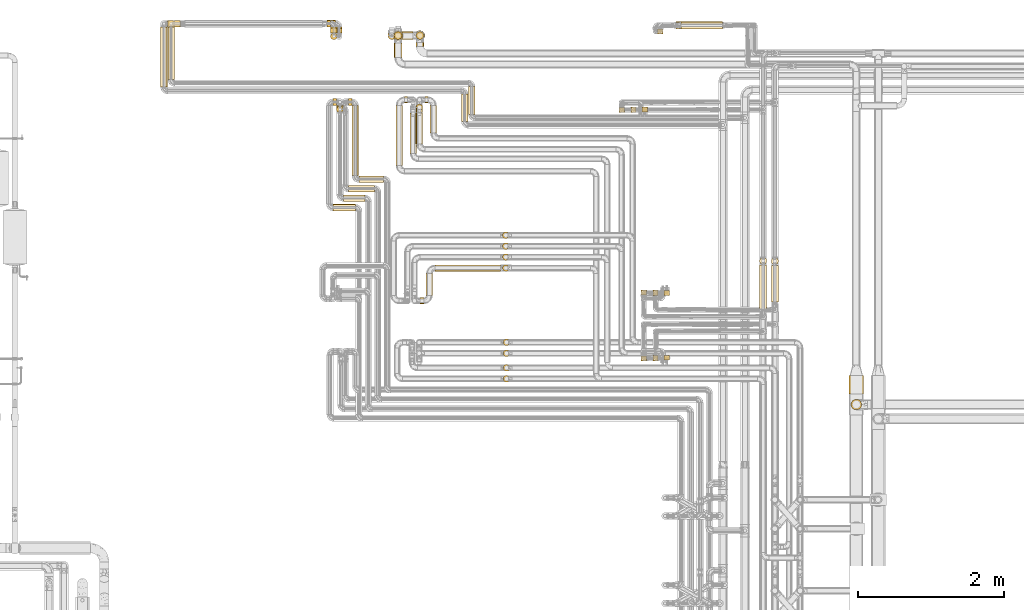
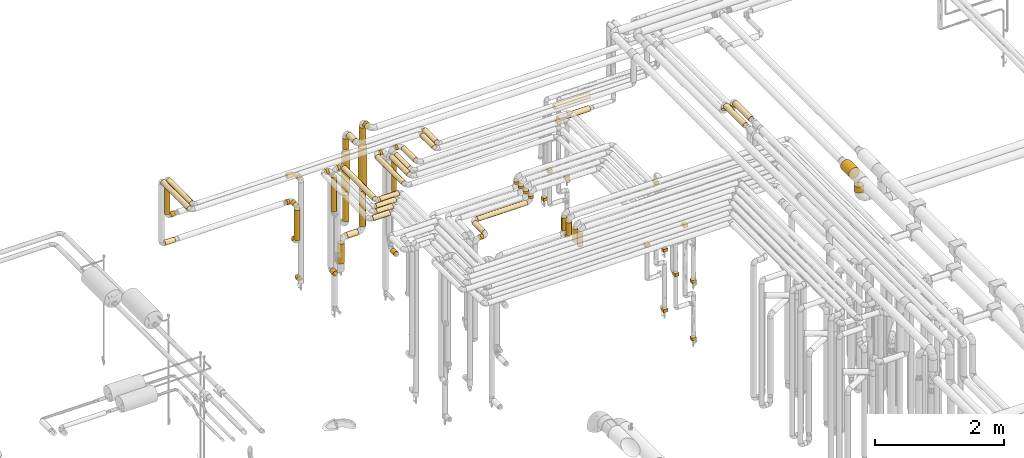
# One storey, part 14 of 827: 73 coverings.
"""IFC2X3 building model written with IfcOpenShell, lengths in millimetres."""

from ifc_helpers import new_model, entity, si_unit, converted_unit, derived_unit, direction, frame, origin, origin_2d_with_axis, place, context, subcontext, project, spatial, rectangle, circle, extrude, element, save


model = new_model("IFC2X3")

# Units and contexts
model_context = context("Model", 3, precision=0.01, world=origin(), true_north=direction((6.12303176911189e-17, 1.0)))
body_context = subcontext(model_context, "Body", "Model", "MODEL_VIEW")
ifc_project = project(units=[si_unit("LENGTHUNIT", "METRE", prefix="MILLI"), si_unit("AREAUNIT", "SQUARE_METRE"), si_unit("VOLUMEUNIT", "CUBIC_METRE"), converted_unit("PLANEANGLEUNIT", "DEGREE", entity("IfcRatioMeasure", 0.0174532925199433), si_unit("PLANEANGLEUNIT", "RADIAN"), dimensions=[0, 0, 0, 0, 0, 0, 0]), si_unit("MASSUNIT", "GRAM", prefix="KILO"), derived_unit("MASSDENSITYUNIT", [(si_unit("MASSUNIT", "GRAM", prefix="KILO"), 1), (si_unit("LENGTHUNIT", "METRE"), -3)]), derived_unit("MOMENTOFINERTIAUNIT", [(si_unit("LENGTHUNIT", "METRE"), 4)]), si_unit("TIMEUNIT", "SECOND"), si_unit("FREQUENCYUNIT", "HERTZ"), si_unit("THERMODYNAMICTEMPERATUREUNIT", "DEGREE_CELSIUS"), derived_unit("THERMALTRANSMITTANCEUNIT", [(si_unit("MASSUNIT", "GRAM", prefix="KILO"), 1), (si_unit("THERMODYNAMICTEMPERATUREUNIT", "KELVIN"), -1), (si_unit("TIMEUNIT", "SECOND"), -3)]), derived_unit("VOLUMETRICFLOWRATEUNIT", [(si_unit("LENGTHUNIT", "METRE"), 3), (si_unit("TIMEUNIT", "SECOND"), -1)]), derived_unit("MASSFLOWRATEUNIT", [(si_unit("MASSUNIT", "GRAM", prefix="KILO"), 1), (si_unit("TIMEUNIT", "SECOND"), -1)]), derived_unit("ROTATIONALFREQUENCYUNIT", [(si_unit("TIMEUNIT", "SECOND"), -1)]), si_unit("ELECTRICCURRENTUNIT", "AMPERE"), si_unit("ELECTRICVOLTAGEUNIT", "VOLT"), si_unit("POWERUNIT", "WATT"), si_unit("FORCEUNIT", "NEWTON", prefix="KILO"), si_unit("ILLUMINANCEUNIT", "LUX"), si_unit("LUMINOUSFLUXUNIT", "LUMEN"), si_unit("LUMINOUSINTENSITYUNIT", "CANDELA"), derived_unit("USERDEFINED", [(si_unit("MASSUNIT", "GRAM", prefix="KILO"), -1), (si_unit("LENGTHUNIT", "METRE"), -2), (si_unit("TIMEUNIT", "SECOND"), 3), (si_unit("LUMINOUSFLUXUNIT", "LUMEN"), 1)]), derived_unit("LINEARVELOCITYUNIT", [(si_unit("LENGTHUNIT", "METRE"), 1), (si_unit("TIMEUNIT", "SECOND"), -1)]), si_unit("PRESSUREUNIT", "PASCAL"), derived_unit("USERDEFINED", [(si_unit("LENGTHUNIT", "METRE"), -2), (si_unit("MASSUNIT", "GRAM", prefix="KILO"), 1), (si_unit("TIMEUNIT", "SECOND"), -2)]), derived_unit("LINEARFORCEUNIT", [(si_unit("MASSUNIT", "GRAM", prefix="KILO"), 1), (si_unit("LENGTHUNIT", "METRE"), 1), (si_unit("TIMEUNIT", "SECOND"), -2), (si_unit("LENGTHUNIT", "METRE"), -1)]), derived_unit("PLANARFORCEUNIT", [(si_unit("MASSUNIT", "GRAM", prefix="KILO"), 1), (si_unit("LENGTHUNIT", "METRE"), 1), (si_unit("TIMEUNIT", "SECOND"), -2), (si_unit("LENGTHUNIT", "METRE"), -2)])], contexts=[model_context])

# Site, building, storey
site_placement = place(None, origin())
site = spatial("IfcSite", under=ifc_project, at=site_placement, CompositionType="ELEMENT")
building_placement = place(site_placement, origin())
building = spatial("IfcBuilding", under=site, at=building_placement, CompositionType="ELEMENT")
storey_placement = place(building_placement, frame((0.0, 0.0, 28200.0)))
storey = spatial("IfcBuildingStorey", under=building, at=storey_placement, Name="08", CompositionType="ELEMENT", Elevation=28200.0)

# Coverings
covering_1_placement = place(storey_placement, frame((30526.84, 19391.43, 1752.25)))
element("IfcCovering", 1, at=covering_1_placement, inside=storey, Name=":ADSK_", ObjectType=":ADSK_", PredefinedType="INSULATION", context=body_context, shape_type="SweptSolid", body=[
    extrude(circle(Radius=46.15, at=origin_2d_with_axis()), frame((47.75, 0.0, 47.75), z_axis=(2.41989448999959e-06, 1.0, 0.0), x_axis=(1.0, -2.41989448999959e-06, 0.0)), (0.0, 0.0, 1.0), 78.9029719647992),
])
covering_2_placement = place(storey_placement, frame((30526.84, 19295.69, 1178.45)))
element("IfcCovering", 2, at=covering_2_placement, inside=storey, Name=":ADSK_", ObjectType=":ADSK_", PredefinedType="INSULATION", context=body_context, shape_type="SweptSolid", body=[
    extrude(circle(Radius=46.15, at=origin_2d_with_axis()), frame((47.75, 47.75, 0.0), z_axis=(0.0, 0.0, 1.0), x_axis=(-1.0, 0.0, 0.0)), (0.0, 0.0, 1.0), 573.551740000017),
])
covering_3_placement = place(storey_placement, frame((30526.84, 19391.43, 1082.7)))
element("IfcCovering", 3, at=covering_3_placement, inside=storey, Name=":ADSK_", ObjectType=":ADSK_", PredefinedType="INSULATION", context=body_context, shape_type="SweptSolid", body=[
    extrude(circle(Radius=46.15, at=origin_2d_with_axis()), frame((47.75, 0.0, 47.75), z_axis=(0.0, 1.0, 0.0), x_axis=(-1.0, 0.0, 0.0)), (0.0, 0.0, 1.0), 57.0000000000087),
])
covering_4_placement = place(storey_placement, frame((30482.2, 19470.59, 1752.25)))
element("IfcCovering", 4, at=covering_4_placement, inside=storey, Name=":ADSK_", ObjectType=":ADSK_", PredefinedType="INSULATION", context=body_context, shape_type="SweptSolid", body=[
    extrude(circle(Radius=46.15, at=origin_2d_with_axis()), frame((0.0, 47.75, 47.75), z_axis=(1.0, 0.0, 0.0), x_axis=(0.0, -1.0, 0.0)), (0.0, 0.0, 1.0), 44.3821107332102),
])
covering_5_placement = place(storey_placement, frame((28288.03, 19468.46, 1752.25)))
element("IfcCovering", 5, at=covering_5_placement, inside=storey, Name=":ADSK_", ObjectType=":ADSK_", PredefinedType="INSULATION", context=body_context, shape_type="SweptSolid", body=[
    extrude(circle(Radius=46.15, at=origin_2d_with_axis()), frame((0.0, 47.75, 47.75), z_axis=(1.0, 0.0, 0.0), x_axis=(0.0, 1.0, 0.0)), (0.0, 0.0, 1.0), 177.183222404817),
])
covering_6_placement = place(storey_placement, frame((28192.29, 18645.5, 2951.76)))
element("IfcCovering", 6, at=covering_6_placement, inside=storey, Name=":ADSK_", ObjectType=":ADSK_", PredefinedType="INSULATION", context=body_context, shape_type="SweptSolid", body=[
    extrude(circle(Radius=46.15, at=origin_2d_with_axis()), frame((47.75, 0.0, 47.75), z_axis=(0.0, 1.0, 0.0), x_axis=(1.0, 0.0, 0.0)), (0.0, 0.0, 1.0), 822.702150799367),
])
covering_7_placement = place(storey_placement, frame((32322.29, 18172.91, 2951.76)))
element("IfcCovering", 7, at=covering_7_placement, inside=storey, Name=":ADSK_", ObjectType=":ADSK_", PredefinedType="INSULATION", context=body_context, shape_type="SweptSolid", body=[
    extrude(circle(Radius=46.15, at=origin_2d_with_axis()), frame((47.75, 0.0, 47.75), z_axis=(0.0, 1.0, 0.0), x_axis=(1.0, 0.0, 0.0)), (0.0, 0.0, 1.0), 376.59487649053),
])
covering_8_placement = place(storey_placement, frame((30594.46, 19391.43, 2252.25)))
element("IfcCovering", 8, at=covering_8_placement, inside=storey, Name=":ADSK_", ObjectType=":ADSK_", PredefinedType="INSULATION", context=body_context, shape_type="SweptSolid", body=[
    extrude(circle(Radius=46.15, at=origin_2d_with_axis()), frame((47.75, 0.0, 47.75), z_axis=(0.0, 1.0, 0.0), x_axis=(1.0, 0.0, 0.0)), (0.0, 0.0, 1.0), 79.0000000000275),
])
covering_9_placement = place(storey_placement, frame((30594.46, 19391.43, 327.25)))
element("IfcCovering", 9, at=covering_9_placement, inside=storey, Name=":ADSK_", ObjectType=":ADSK_", PredefinedType="INSULATION", context=body_context, shape_type="SweptSolid", body=[
    extrude(circle(Radius=46.15, at=origin_2d_with_axis()), frame((47.75, 0.0, 47.75), z_axis=(0.0, 1.0, 0.0), x_axis=(-1.0, 0.0, 0.0)), (0.0, 0.0, 1.0), 56.9999999999892),
])
covering_10_placement = place(storey_placement, frame((30482.2, 19470.69, 2252.25)))
element("IfcCovering", 10, at=covering_10_placement, inside=storey, Name=":ADSK_", ObjectType=":ADSK_", PredefinedType="INSULATION", context=body_context, shape_type="SweptSolid", body=[
    extrude(circle(Radius=46.15, at=origin_2d_with_axis()), frame((0.0, 47.75, 47.75), z_axis=(1.0, 0.0, 0.0), x_axis=(0.0, -1.0, 0.0)), (0.0, 0.0, 1.0), 112.000000000009),
])
covering_11_placement = place(storey_placement, frame((28292.16, 19468.46, 2347.98)))
element("IfcCovering", 11, at=covering_11_placement, inside=storey, Name=":ADSK_", ObjectType=":ADSK_", PredefinedType="INSULATION", context=body_context, shape_type="SweptSolid", body=[
    extrude(circle(Radius=46.15, at=origin_2d_with_axis()), frame((48.06, 47.75, 0.02), z_axis=(-0.000526508369684798, 0.0, 0.999999861394459), x_axis=(0.999999861394459, 0.0, 0.000526508369684798)), (0.0, 0.0, 1.0), 603.906027666182),
])
covering_12_placement = place(storey_placement, frame((28388.22, 19468.46, 2252.25)))
element("IfcCovering", 12, at=covering_12_placement, inside=storey, Name=":ADSK_", ObjectType=":ADSK_", PredefinedType="INSULATION", context=body_context, shape_type="SweptSolid", body=[
    extrude(circle(Radius=46.15, at=origin_2d_with_axis()), frame((0.0, 47.75, 47.75), z_axis=(1.0, 0.0, 0.0), x_axis=(0.0, 1.0, 0.0)), (0.0, 0.0, 1.0), 72.0000000000053),
])
covering_13_placement = place(storey_placement, frame((28292.14, 18748.0, 2952.16)))
element("IfcCovering", 13, at=covering_13_placement, inside=storey, Name=":ADSK_", ObjectType=":ADSK_", PredefinedType="INSULATION", context=body_context, shape_type="SweptSolid", body=[
    extrude(circle(Radius=46.15, at=origin_2d_with_axis()), frame((47.75, 0.0, 47.75), z_axis=(0.0, 1.0, 0.0), x_axis=(1.0, 0.0, 0.0)), (0.0, 0.0, 1.0), 720.202150799347),
])
covering_14_placement = place(storey_placement, frame((32419.78, 18272.95, 2952.16)))
element("IfcCovering", 14, at=covering_14_placement, inside=storey, Name=":ADSK_", ObjectType=":ADSK_", PredefinedType="INSULATION", context=body_context, shape_type="SweptSolid", body=[
    extrude(circle(Radius=46.15, at=origin_2d_with_axis()), frame((47.75, 0.0, 47.75), z_axis=(0.0, 1.0, 0.0), x_axis=(1.0, 0.0, 0.0)), (0.0, 0.0, 1.0), 379.054374559309),
])
covering_15_placement = place(storey_placement, frame((30773.07, 17203.46, 2952.25)))
element("IfcCovering", 15, at=covering_15_placement, inside=storey, Name=":ADSK_", ObjectType=":ADSK_", PredefinedType="INSULATION", context=body_context, shape_type="SweptSolid", body=[
    extrude(circle(Radius=46.15, at=origin_2d_with_axis()), frame((0.0, 47.75, 47.75), z_axis=(1.0, 0.0, 0.0), x_axis=(0.0, 1.0, 0.0)), (0.0, 0.0, 1.0), 355.449929999979),
])
covering_16_placement = place(storey_placement, frame((30705.05, 17073.46, 2952.25)))
element("IfcCovering", 16, at=covering_16_placement, inside=storey, Name=":ADSK_", ObjectType=":ADSK_", PredefinedType="INSULATION", context=body_context, shape_type="SweptSolid", body=[
    extrude(circle(Radius=46.15, at=origin_2d_with_axis()), frame((0.0, 47.75, 47.75), z_axis=(1.0, 0.0, 0.0), x_axis=(0.0, 1.0, 0.0)), (0.0, 0.0, 1.0), 293.47319999997),
])
covering_17_placement = place(storey_placement, frame((30609.3, 18293.46, 2298.45)))
element("IfcCovering", 17, at=covering_17_placement, inside=storey, Name=":ADSK_", ObjectType=":ADSK_", PredefinedType="INSULATION", context=body_context, shape_type="SweptSolid", body=[
    extrude(circle(Radius=46.15, at=origin_2d_with_axis()), frame((47.75, 47.75, 0.0), z_axis=(0.0, 0.0, 1.0), x_axis=(0.0, -1.0, 0.0)), (0.0, 0.0, 1.0), 653.551739999973),
])
covering_18_placement = place(storey_placement, frame((30915.6, 17333.46, 2952.25)))
element("IfcCovering", 18, at=covering_18_placement, inside=storey, Name=":ADSK_", ObjectType=":ADSK_", PredefinedType="INSULATION", context=body_context, shape_type="SweptSolid", body=[
    extrude(circle(Radius=46.15, at=origin_2d_with_axis()), frame((0.0, 47.75, 47.75), z_axis=(1.0, 0.0, 0.0), x_axis=(0.0, 1.0, 0.0)), (0.0, 0.0, 1.0), 342.918088784113),
])
covering_19_placement = place(storey_placement, frame((30819.86, 17429.2, 2952.25)))
element("IfcCovering", 19, at=covering_19_placement, inside=storey, Name=":ADSK_", ObjectType=":ADSK_", PredefinedType="INSULATION", context=body_context, shape_type="SweptSolid", body=[
    extrude(circle(Radius=46.15, at=origin_2d_with_axis()), frame((47.75, 0.0, 47.75), z_axis=(0.0, 1.0, 0.0), x_axis=(-1.0, 0.0, 0.0)), (0.0, 0.0, 1.0), 963.999999953802),
])
covering_20_placement = place(storey_placement, frame((30773.07, 18393.46, 2952.25)))
element("IfcCovering", 20, at=covering_20_placement, inside=storey, Name=":ADSK_", ObjectType=":ADSK_", PredefinedType="INSULATION", context=body_context, shape_type="SweptSolid", body=[
    extrude(circle(Radius=46.15, at=origin_2d_with_axis()), frame((0.0, 47.75, 47.75), z_axis=(1.0, 0.0, 0.0), x_axis=(0.0, -1.0, 0.0)), (0.0, 0.0, 1.0), 46.5318412158456),
])
covering_21_placement = place(storey_placement, frame((30563.05, 16943.46, 2952.25)))
element("IfcCovering", 21, at=covering_21_placement, inside=storey, Name=":ADSK_", ObjectType=":ADSK_", PredefinedType="INSULATION", context=body_context, shape_type="SweptSolid", body=[
    extrude(circle(Radius=46.15, at=origin_2d_with_axis()), frame((0.0, 47.75, 47.75), z_axis=(1.0, 0.0, 0.0), x_axis=(0.0, 1.0, 0.0)), (0.0, 0.0, 1.0), 305.473199999971),
])
covering_22_placement = place(storey_placement, frame((30563.05, 18393.46, 2952.25)))
element("IfcCovering", 22, at=covering_22_placement, inside=storey, Name=":ADSK_", ObjectType=":ADSK_", PredefinedType="INSULATION", context=body_context, shape_type="SweptSolid", body=[
    extrude(circle(Radius=46.15, at=origin_2d_with_axis()), frame((0.0, 47.75, 47.75), z_axis=(1.0, 0.0, 0.0), x_axis=(0.0, 1.0, 0.0)), (0.0, 0.0, 1.0), 46.0000000000285),
])
covering_23_placement = place(storey_placement, frame((30609.3, 18293.2, 1082.7)))
element("IfcCovering", 23, at=covering_23_placement, inside=storey, Name=":ADSK_", ObjectType=":ADSK_", PredefinedType="INSULATION", context=body_context, shape_type="SweptSolid", body=[
    extrude(circle(Radius=46.15, at=origin_2d_with_axis()), frame((47.75, 0.0, 47.75), z_axis=(0.0, 1.0, 0.0), x_axis=(1.0, 0.0, 0.0)), (0.0, 0.0, 1.0), 99.999999953832),
])
covering_24_placement = place(storey_placement, frame((31423.07, 17567.2, 2953.4)))
element("IfcCovering", 24, at=covering_24_placement, inside=storey, Name=":ADSK_", ObjectType=":ADSK_", PredefinedType="INSULATION", context=body_context, shape_type="SweptSolid", body=[
    extrude(circle(Radius=45.0, at=origin_2d_with_axis()), frame((46.6, 0.0, 46.6), z_axis=(0.0, 1.0, 0.0), x_axis=(-1.0, 0.0, 0.0)), (0.0, 0.0, 1.0), 828.00000018509),
])
covering_25_placement = place(storey_placement, frame((31545.66, 18424.61, 2953.4)))
element("IfcCovering", 25, at=covering_25_placement, inside=storey, Name=":ADSK_", ObjectType=":ADSK_", PredefinedType="INSULATION", context=body_context, shape_type="SweptSolid", body=[
    extrude(circle(Radius=44.9999999999983, at=origin_2d_with_axis()), frame((0.0, 46.6, 46.6), z_axis=(1.0, -7.92292970193888e-09, 0.0), x_axis=(7.92292970193888e-09, 1.0, 0.0)), (0.0, 0.0, 1.0), 39.999982254181),
])
covering_26_placement = place(storey_placement, frame((31615.07, 17736.2, 2953.4)))
element("IfcCovering", 26, at=covering_26_placement, inside=storey, Name=":ADSK_", ObjectType=":ADSK_", PredefinedType="INSULATION", context=body_context, shape_type="SweptSolid", body=[
    extrude(circle(Radius=45.0, at=origin_2d_with_axis()), frame((46.6, 0.0, 46.6), z_axis=(0.0, 1.0, 0.0), x_axis=(-1.0, 0.0, 0.0)), (0.0, 0.0, 1.0), 554.746270361101),
])
covering_27_placement = place(storey_placement, frame((37674.7, 14213.02, 2652.0)))
element("IfcCovering", 27, at=covering_27_placement, inside=storey, Name=":ADSK_", ObjectType=":ADSK_", PredefinedType="INSULATION", context=body_context, shape_type="SweptSolid", body=[
    extrude(circle(Radius=72.0, at=origin_2d_with_axis()), frame((73.6, 73.6, 0.0), z_axis=(-6.40496036329722e-06, 5.83222826609778e-05, 1.0), x_axis=(0.0, 1.0, -5.83222826621741e-05)), (0.0, 0.0, 1.0), 117.908342493745),
])
covering_28_placement = place(storey_placement, frame((37649.2, 14429.62, 2800.85)))
element("IfcCovering", 28, at=covering_28_placement, inside=storey, Name=":ADSK_", ObjectType=":ADSK_", PredefinedType="INSULATION", context=body_context, shape_type="SweptSolid", body=[
    extrude(circle(Radius=97.5, at=origin_2d_with_axis()), frame((99.1, 0.0, 99.1), z_axis=(0.0, 1.0, 3.7942079230377e-05), x_axis=(1.0, 0.0, 0.0)), (0.0, 0.0, 1.0), 258.098078858666),
])
covering_29_placement = place(storey_placement, frame((32898.44, 14743.41, 3076.0)))
element("IfcCovering", 29, at=covering_29_placement, inside=storey, Name=":ADSK_", ObjectType=":ADSK_", PredefinedType="INSULATION", context=body_context, shape_type="SweptSolid", body=[
    extrude(circle(Radius=45.0, at=origin_2d_with_axis()), frame((46.6, 46.6, 0.0), z_axis=(0.0, 0.0, 1.0), x_axis=(0.0, -1.0, 0.0)), (0.0, 0.0, 1.0), 248.000000000013),
])
covering_30_placement = place(storey_placement, frame((32898.44, 14593.41, 3076.0)))
element("IfcCovering", 30, at=covering_30_placement, inside=storey, Name=":ADSK_", ObjectType=":ADSK_", PredefinedType="INSULATION", context=body_context, shape_type="SweptSolid", body=[
    extrude(circle(Radius=45.0, at=origin_2d_with_axis()), frame((46.6, 46.6, 0.0), z_axis=(0.0, 0.0, 1.0), x_axis=(0.0, -1.0, 0.0)), (0.0, 0.0, 1.0), 248.000000000022),
])
covering_31_placement = place(storey_placement, frame((31961.25, 16114.61, 2953.4)))
element("IfcCovering", 31, at=covering_31_placement, inside=storey, Name=":ADSK_", ObjectType=":ADSK_", PredefinedType="INSULATION", context=body_context, shape_type="SweptSolid", body=[
    extrude(circle(Radius=45.0, at=origin_2d_with_axis()), frame((0.0, 46.6, 46.6), z_axis=(1.0, 0.0, 0.0), x_axis=(0.0, -1.0, 0.0)), (0.0, 0.0, 1.0), 897.780008999999),
])
covering_32_placement = place(storey_placement, frame((32888.44, 16114.61, 3076.0)))
element("IfcCovering", 32, at=covering_32_placement, inside=storey, Name=":ADSK_", ObjectType=":ADSK_", PredefinedType="INSULATION", context=body_context, shape_type="SweptSolid", body=[
    extrude(circle(Radius=45.0, at=origin_2d_with_axis()), frame((46.6, 46.6, 0.0), z_axis=(0.0, 0.0, 1.0), x_axis=(0.0, -1.0, 0.0)), (0.0, 0.0, 1.0), 48.0000000000237),
])
covering_33_placement = place(storey_placement, frame((31838.66, 15787.2, 2953.4)))
element("IfcCovering", 33, at=covering_33_placement, inside=storey, Name=":ADSK_", ObjectType=":ADSK_", PredefinedType="INSULATION", context=body_context, shape_type="SweptSolid", body=[
    extrude(circle(Radius=45.0, at=origin_2d_with_axis()), frame((46.6, 0.0, 46.6), z_axis=(0.0, 1.0, 0.0), x_axis=(1.0, 0.0, 0.0)), (0.0, 0.0, 1.0), 298.000000000004),
])
covering_34_placement = place(storey_placement, frame((31756.25, 15664.61, 2953.4)))
element("IfcCovering", 34, at=covering_34_placement, inside=storey, Name=":ADSK_", ObjectType=":ADSK_", PredefinedType="INSULATION", context=body_context, shape_type="SweptSolid", body=[
    extrude(circle(Radius=45.0, at=origin_2d_with_axis()), frame((0.0, 46.6, 46.6), z_axis=(1.0, 0.0, 0.0), x_axis=(0.0, -1.0, 0.0)), (0.0, 0.0, 1.0), 53.0000000000096),
])
covering_35_placement = place(storey_placement, frame((32888.44, 16264.61, 3076.0)))
element("IfcCovering", 35, at=covering_35_placement, inside=storey, Name=":ADSK_", ObjectType=":ADSK_", PredefinedType="INSULATION", context=body_context, shape_type="SweptSolid", body=[
    extrude(circle(Radius=45.0, at=origin_2d_with_axis()), frame((46.6, 46.6, 0.0), z_axis=(0.0, 0.0, 1.0), x_axis=(0.0, -1.0, 0.0)), (0.0, 0.0, 1.0), 48.0000000000237),
])
covering_36_placement = place(storey_placement, frame((36418.12, 15593.5, 3499.4)))
element("IfcCovering", 36, at=covering_36_placement, inside=storey, Name=":ADSK_", ObjectType=":ADSK_", PredefinedType="INSULATION", context=body_context, shape_type="SweptSolid", body=[
    extrude(circle(Radius=49.0, at=origin_2d_with_axis()), frame((50.6, 0.0, 50.6), z_axis=(0.0, 1.0, 0.0), x_axis=(-1.0, 0.0, 0.0)), (0.0, 0.0, 1.0), 608.434591895195),
])
covering_37_placement = place(storey_placement, frame((34789.4, 15793.05, 1681.0)))
element("IfcCovering", 37, at=covering_37_placement, inside=storey, Name=":ADSK_", ObjectType=":ADSK_", PredefinedType="INSULATION", context=body_context, shape_type="SweptSolid", body=[
    extrude(rectangle(XDim=76.8999999999955, YDim=67.450000000002, at=origin_2d_with_axis()), frame((38.45, 33.73, 0.0)), (0.0, 0.0, 1.0), 57.9999999999955),
])
covering_38_placement = place(storey_placement, frame((34954.43, 14886.46, 2551.0)))
element("IfcCovering", 38, at=covering_38_placement, inside=storey, Name=":ADSK_", ObjectType=":ADSK_", PredefinedType="INSULATION", context=body_context, shape_type="SweptSolid", body=[
    extrude(rectangle(XDim=67.4499999999977, YDim=76.900000000002, at=origin_2d_with_axis()), frame((33.73, 38.45, 0.0)), (0.0, 0.0, 1.0), 57.9999999999955),
])
covering_39_placement = place(storey_placement, frame((35104.43, 14895.91, 343.0)))
element("IfcCovering", 39, at=covering_39_placement, inside=storey, Name=":ADSK_", ObjectType=":ADSK_", PredefinedType="INSULATION", context=body_context, shape_type="SweptSolid", body=[
    extrude(rectangle(XDim=76.8999999999955, YDim=67.450000000002, at=origin_2d_with_axis()), frame((38.45, 33.72, 0.0)), (0.0, 0.0, 1.0), 57.9999999999955),
])
covering_40_placement = place(storey_placement, frame((36418.12, 16208.34, 3456.89)))
element("IfcCovering", 40, at=covering_40_placement, inside=storey, Name=":ADSK_", ObjectType=":ADSK_", PredefinedType="INSULATION", context=body_context, shape_type="SweptSolid", body=[
    extrude(circle(Radius=49.0, at=origin_2d_with_axis()), frame((50.6, 50.6, 0.0)), (0.0, 0.0, 1.0), 36.1093387780081),
])
covering_41_placement = place(storey_placement, frame((34651.97, 18296.46, 2551.0)))
element("IfcCovering", 41, at=covering_41_placement, inside=storey, Name=":ADSK_", ObjectType=":ADSK_", PredefinedType="INSULATION", context=body_context, shape_type="SweptSolid", body=[
    extrude(rectangle(XDim=67.4499999999977, YDim=76.900000000002, at=origin_2d_with_axis()), frame((33.72, 38.45, 0.0)), (0.0, 0.0, 1.0), 57.9999999999955),
])
covering_42_placement = place(storey_placement, frame((34801.97, 18305.91, 343.0)))
element("IfcCovering", 42, at=covering_42_placement, inside=storey, Name=":ADSK_", ObjectType=":ADSK_", PredefinedType="INSULATION", context=body_context, shape_type="SweptSolid", body=[
    extrude(rectangle(XDim=76.8999999999955, YDim=67.450000000002, at=origin_2d_with_axis()), frame((38.45, 33.73, 0.0)), (0.0, 0.0, 1.0), 57.9999999999955),
])
covering_43_placement = place(storey_placement, frame((35339.02, 19444.01, 1649.4)))
element("IfcCovering", 43, at=covering_43_placement, inside=storey, Name=":ADSK_", ObjectType=":ADSK_", PredefinedType="INSULATION", context=body_context, shape_type="SweptSolid", body=[
    extrude(circle(Radius=49.0, at=origin_2d_with_axis()), frame((0.0, 50.6, 50.6), z_axis=(1.0, 3.39871971237953e-08, 0.0), x_axis=(3.39871971237953e-08, -1.0, 0.0)), (0.0, 0.0, 1.0), 572.000000000022),
])
covering_44_placement = place(storey_placement, frame((35017.59, 19374.98, 309.5)))
element("IfcCovering", 44, at=covering_44_placement, inside=storey, Name=":ADSK_", ObjectType=":ADSK_", PredefinedType="INSULATION", context=body_context, shape_type="SweptSolid", body=[
    extrude(rectangle(XDim=76.8999999999955, YDim=67.450000000002, at=origin_2d_with_axis()), frame((38.45, 33.73, 0.0)), (0.0, 0.0, 1.0), 57.9999999999955),
])
covering_45_placement = place(storey_placement, frame((36579.05, 16204.89, 3456.89)))
element("IfcCovering", 45, at=covering_45_placement, inside=storey, Name=":ADSK_", ObjectType=":ADSK_", PredefinedType="INSULATION", context=body_context, shape_type="SweptSolid", body=[
    extrude(circle(Radius=49.0, at=origin_2d_with_axis()), frame((50.6, 50.6, 0.0), z_axis=(0.0, 0.0, 1.0), x_axis=(0.0, -1.0, 0.0)), (0.0, 0.0, 1.0), 36.1093387779778),
])
covering_46_placement = place(storey_placement, frame((36579.05, 15693.54, 3499.4)))
element("IfcCovering", 46, at=covering_46_placement, inside=storey, Name=":ADSK_", ObjectType=":ADSK_", PredefinedType="INSULATION", context=body_context, shape_type="SweptSolid", body=[
    extrude(circle(Radius=49.0, at=origin_2d_with_axis()), frame((50.6, 0.0, 50.6), z_axis=(0.0, 1.0, 0.0), x_axis=(1.0, 0.0, 0.0)), (0.0, 0.0, 1.0), 504.947450164842),
])
covering_47_placement = place(storey_placement, frame((34954.43, 15783.6, 2821.0)))
element("IfcCovering", 47, at=covering_47_placement, inside=storey, Name=":ADSK_", ObjectType=":ADSK_", PredefinedType="INSULATION", context=body_context, shape_type="SweptSolid", body=[
    extrude(rectangle(XDim=67.4499999999977, YDim=76.900000000002, at=origin_2d_with_axis()), frame((33.72, 38.45, 0.0)), (0.0, 0.0, 1.0), 57.9999999999955),
])
for number, where, name in (
    (48, (34789.4, 14886.46, 1681.0), ":ADSK_"),
    (49, (35104.43, 15783.6, 343.0), ":ADSK_"),
    (50, (34486.94, 18296.46, 1681.0), ":ADSK_"),
):
    element("IfcCovering", number, at=place(storey_placement, frame(where)), inside=storey, Name=name, ObjectType=":ADSK_", PredefinedType="INSULATION", context=body_context, shape_type="SweptSolid", body=[
        extrude(rectangle(XDim=76.8999999999955, YDim=67.450000000002, at=origin_2d_with_axis()), frame((38.45, 33.73, 0.0)), (0.0, 0.0, 1.0), 57.9999999999955),
    ])
covering_48_placement = place(storey_placement, frame((35275.02, 19444.01, 1899.4)))
element("IfcCovering", 51, at=covering_48_placement, inside=storey, Name=":ADSK_", ObjectType=":ADSK_", PredefinedType="INSULATION", context=body_context, shape_type="SweptSolid", body=[
    extrude(circle(Radius=49.0, at=origin_2d_with_axis()), frame((0.0, 50.6, 50.6), z_axis=(1.0, 1.52835492052496e-08, 0.0), x_axis=(1.52835492052496e-08, -1.0, 0.0)), (0.0, 0.0, 1.0), 635.999999999998),
])
covering_49_placement = place(storey_placement, frame((31400.81, 19052.24, 2845.49)))
element("IfcCovering", 52, at=covering_49_placement, inside=storey, Name=":ADSK_", ObjectType=":ADSK_", PredefinedType="INSULATION", context=body_context, shape_type="SweptSolid", body=[
    extrude(circle(Radius=53.0, at=origin_2d_with_axis()), frame((54.6, 0.0, 54.6), z_axis=(0.0, 1.0, 0.0), x_axis=(-1.0, 0.0, 0.0)), (0.0, 0.0, 1.0), 201.196730959911),
])
covering_50_placement = place(storey_placement, frame((31384.81, 19282.84, 1805.45)))
element("IfcCovering", 53, at=covering_50_placement, inside=storey, Name=":ADSK_", ObjectType=":ADSK_", PredefinedType="INSULATION", context=body_context, shape_type="SweptSolid", body=[
    extrude(circle(Radius=69.0, at=origin_2d_with_axis()), frame((70.6, 70.6, 0.0)), (0.0, 0.0, 1.0), 714.55174000002),
])
covering_51_placement = place(storey_placement, frame((31400.81, 19298.84, 1225.45)))
element("IfcCovering", 54, at=covering_51_placement, inside=storey, Name=":ADSK_", ObjectType=":ADSK_", PredefinedType="INSULATION", context=body_context, shape_type="SweptSolid", body=[
    extrude(circle(Radius=53.0, at=origin_2d_with_axis()), frame((54.6, 54.6, 0.0), z_axis=(0.0, 0.0, 1.0), x_axis=(-1.0, 0.0, 0.0)), (0.0, 0.0, 1.0), 500.000000000008),
])
covering_52_placement = place(storey_placement, frame((34801.97, 18305.91, 1434.5)))
element("IfcCovering", 55, at=covering_52_placement, inside=storey, Name=":ADSK_", ObjectType=":ADSK_", PredefinedType="INSULATION", context=body_context, shape_type="SweptSolid", body=[
    extrude(rectangle(XDim=76.8999999999955, YDim=67.450000000002, at=origin_2d_with_axis()), frame((38.45, 33.73, 0.0)), (0.0, 0.0, 1.0), 57.9999999999955),
])
covering_53_placement = place(storey_placement, frame((35104.43, 15783.6, 1491.85)))
element("IfcCovering", 56, at=covering_53_placement, inside=storey, Name=":ADSK_", ObjectType=":ADSK_", PredefinedType="INSULATION", context=body_context, shape_type="SweptSolid", body=[
    extrude(rectangle(XDim=76.8999999999955, YDim=67.450000000002, at=origin_2d_with_axis()), frame((38.45, 33.72, 0.0)), (0.0, 0.0, 1.0), 57.9999999999955),
])
covering_54_placement = place(storey_placement, frame((35104.43, 14895.91, 1434.5)))
element("IfcCovering", 57, at=covering_54_placement, inside=storey, Name=":ADSK_", ObjectType=":ADSK_", PredefinedType="INSULATION", context=body_context, shape_type="SweptSolid", body=[
    extrude(rectangle(XDim=76.8999999999955, YDim=67.450000000002, at=origin_2d_with_axis()), frame((38.45, 33.73, 0.0)), (0.0, 0.0, 1.0), 57.9999999999955),
])
covering_55_placement = place(storey_placement, frame((31701.11, 19202.72, 2945.4)))
element("IfcCovering", 58, at=covering_55_placement, inside=storey, Name=":ADSK_", ObjectType=":ADSK_", PredefinedType="INSULATION", context=body_context, shape_type="SweptSolid", body=[
    extrude(circle(Radius=53.0, at=origin_2d_with_axis()), frame((54.6, 0.0, 54.6), z_axis=(0.0, 1.0, 0.0), x_axis=(-1.0, 0.0, 0.0)), (0.0, 0.0, 1.0), 55.7170496217003),
])
covering_56_placement = place(storey_placement, frame((31701.11, 19298.84, 2600.0)))
element("IfcCovering", 59, at=covering_56_placement, inside=storey, Name=":ADSK_", ObjectType=":ADSK_", PredefinedType="INSULATION", context=body_context, shape_type="SweptSolid", body=[
    extrude(circle(Radius=53.0, at=origin_2d_with_axis()), frame((54.6, 54.6, 0.0), z_axis=(0.0, 0.0, 1.0), x_axis=(-1.0, 0.0, 0.0)), (0.0, 0.0, 1.0), 305.000000000013),
])
covering_57_placement = place(storey_placement, frame((31313.81, 19298.84, 451.0)))
element("IfcCovering", 60, at=covering_57_placement, inside=storey, Name=":ADSK_", ObjectType=":ADSK_", PredefinedType="INSULATION", context=body_context, shape_type="SweptSolid", body=[
    extrude(circle(Radius=53.0, at=origin_2d_with_axis()), frame((54.6, 54.6, 0.0)), (0.0, 0.0, 1.0), 379.261639999987),
])
covering_58_placement = place(storey_placement, frame((31463.41, 19298.84, 870.67)))
element("IfcCovering", 61, at=covering_58_placement, inside=storey, Name=":ADSK_", ObjectType=":ADSK_", PredefinedType="INSULATION", context=body_context, shape_type="SweptSolid", body=[
    extrude(circle(Radius=53.0, at=origin_2d_with_axis()), frame((0.0, 54.6, 54.6), z_axis=(1.0, 0.0, 0.0), x_axis=(0.0, 1.0, 0.0)), (0.0, 0.0, 1.0), 197.500000000011),
])
covering_59_placement = place(storey_placement, frame((31701.31, 19298.84, 1020.26)))
element("IfcCovering", 62, at=covering_59_placement, inside=storey, Name=":ADSK_", ObjectType=":ADSK_", PredefinedType="INSULATION", context=body_context, shape_type="SweptSolid", body=[
    extrude(circle(Radius=53.0, at=origin_2d_with_axis()), frame((54.6, 54.6, 0.0), z_axis=(0.0, 0.0, 1.0), x_axis=(0.0, 1.0, 0.0)), (0.0, 0.0, 1.0), 676.738359999959),
])
covering_60_placement = place(storey_placement, frame((31702.07, 17867.2, 2953.4)))
element("IfcCovering", 63, at=covering_60_placement, inside=storey, Name=":ADSK_", ObjectType=":ADSK_", PredefinedType="INSULATION", context=body_context, shape_type="SweptSolid", body=[
    extrude(circle(Radius=45.0, at=origin_2d_with_axis()), frame((46.6, 0.0, 46.6), z_axis=(0.0, 1.0, 0.0), x_axis=(-1.0, 0.0, 0.0)), (0.0, 0.0, 1.0), 423.74627954619),
])
covering_61_placement = place(storey_placement, frame((31894.07, 18017.2, 2953.4)))
element("IfcCovering", 64, at=covering_61_placement, inside=storey, Name=":ADSK_", ObjectType=":ADSK_", PredefinedType="INSULATION", context=body_context, shape_type="SweptSolid", body=[
    extrude(circle(Radius=45.0, at=origin_2d_with_axis()), frame((46.6, 0.0, 46.6), z_axis=(0.0, 1.0, 0.0), x_axis=(1.0, 0.0, 0.0)), (0.0, 0.0, 1.0), 378.000008868197),
])
covering_62_placement = place(storey_placement, frame((31824.66, 18424.61, 2953.4)))
element("IfcCovering", 65, at=covering_62_placement, inside=storey, Name=":ADSK_", ObjectType=":ADSK_", PredefinedType="INSULATION", context=body_context, shape_type="SweptSolid", body=[
    extrude(circle(Radius=45.0, at=origin_2d_with_axis()), frame((0.0, 46.6, 46.6), z_axis=(1.0, 0.0, 0.0), x_axis=(0.0, -1.0, 0.0)), (0.0, 0.0, 1.0), 40.0000000346946),
])
for number, where, name in (
    (66, (32898.44, 15093.41, 3076.0), ":ADSK_"),
    (67, (32898.44, 14943.41, 3076.0), ":ADSK_"),
):
    element("IfcCovering", number, at=place(storey_placement, frame(where)), inside=storey, Name=name, ObjectType=":ADSK_", PredefinedType="INSULATION", context=body_context, shape_type="SweptSolid", body=[
        extrude(circle(Radius=45.0, at=origin_2d_with_axis()), frame((46.6, 46.6, 0.0), z_axis=(0.0, 0.0, 1.0), x_axis=(0.0, 1.0, 0.0)), (0.0, 0.0, 1.0), 248.000000000013),
    ])
for number, where, name in (
    (68, (32888.44, 16414.61, 3076.0), ":ADSK_"),
    (69, (32888.44, 16564.61, 3076.0), ":ADSK_"),
):
    element("IfcCovering", number, at=place(storey_placement, frame(where)), inside=storey, Name=name, ObjectType=":ADSK_", PredefinedType="INSULATION", context=body_context, shape_type="SweptSolid", body=[
        extrude(circle(Radius=45.0, at=origin_2d_with_axis()), frame((46.6, 46.6, 0.0), z_axis=(0.0, 0.0, 1.0), x_axis=(0.0, -1.0, 0.0)), (0.0, 0.0, 1.0), 48.0000000000237),
    ])
covering_63_placement = place(storey_placement, frame((31702.07, 18295.2, 1073.53)))
element("IfcCovering", 70, at=covering_63_placement, inside=storey, Name=":ADSK_", ObjectType=":ADSK_", PredefinedType="INSULATION", context=body_context, shape_type="SweptSolid", body=[
    extrude(circle(Radius=45.0, at=origin_2d_with_axis()), frame((46.6, 0.0, 46.6), z_axis=(0.0, 1.0, 0.0), x_axis=(1.0, 0.0, 0.0)), (0.0, 0.0, 1.0), 99.9999999999989),
])
covering_64_placement = place(storey_placement, frame((31702.07, 18320.35, 2281.01)))
element("IfcCovering", 71, at=covering_64_placement, inside=storey, Name=":ADSK_", ObjectType=":ADSK_", PredefinedType="INSULATION", context=body_context, shape_type="SweptSolid", body=[
    extrude(circle(Radius=45.0, at=origin_2d_with_axis()), frame((46.6, 46.6, 0.0), z_axis=(0.0, 0.0, 1.0), x_axis=(-1.0, 0.0, 0.0)), (0.0, 0.0, 1.0), 642.989986202028),
])
covering_65_placement = place(storey_placement, frame((31685.11, 19282.84, 1777.0)))
element("IfcCovering", 72, at=covering_65_placement, inside=storey, Name=":ADSK_", ObjectType=":ADSK_", PredefinedType="INSULATION", context=body_context, shape_type="SweptSolid", body=[
    extrude(circle(Radius=69.0, at=origin_2d_with_axis()), frame((70.6, 70.6, 0.0), z_axis=(0.0, 0.0, 1.0), x_axis=(0.0, -1.0, 0.0)), (0.0, 0.0, 1.0), 743.000000000004),
])
covering_66_placement = place(storey_placement, frame((31400.81, 19298.84, 2600.0)))
element("IfcCovering", 73, at=covering_66_placement, inside=storey, Name=":ADSK_", ObjectType=":ADSK_", PredefinedType="INSULATION", context=body_context, shape_type="SweptSolid", body=[
    extrude(circle(Radius=53.0, at=origin_2d_with_axis()), frame((54.6, 54.6, 0.0), z_axis=(0.0, 0.0, 1.0), x_axis=(0.0, -1.0, 0.0)), (0.0, 0.0, 1.0), 200.080617222013),
])

save(model, "model.ifc")
